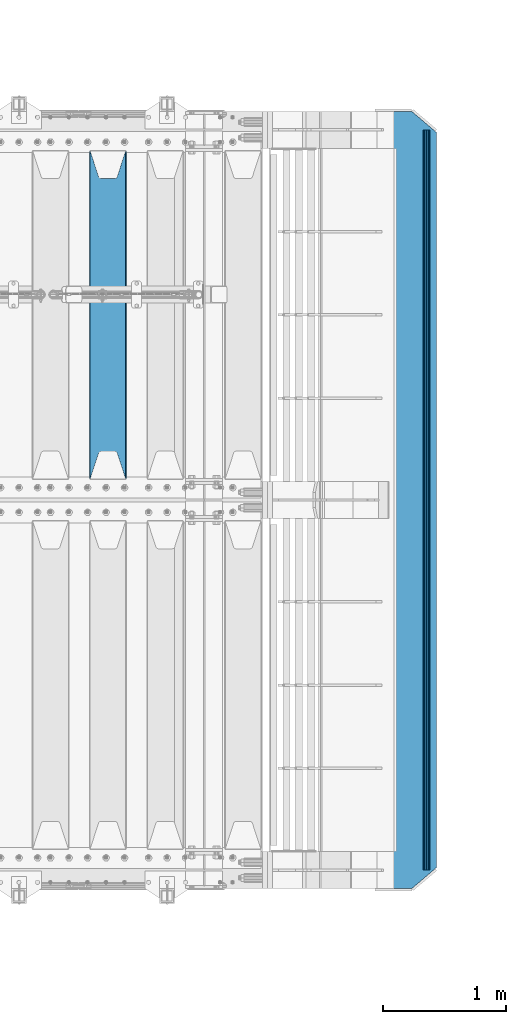
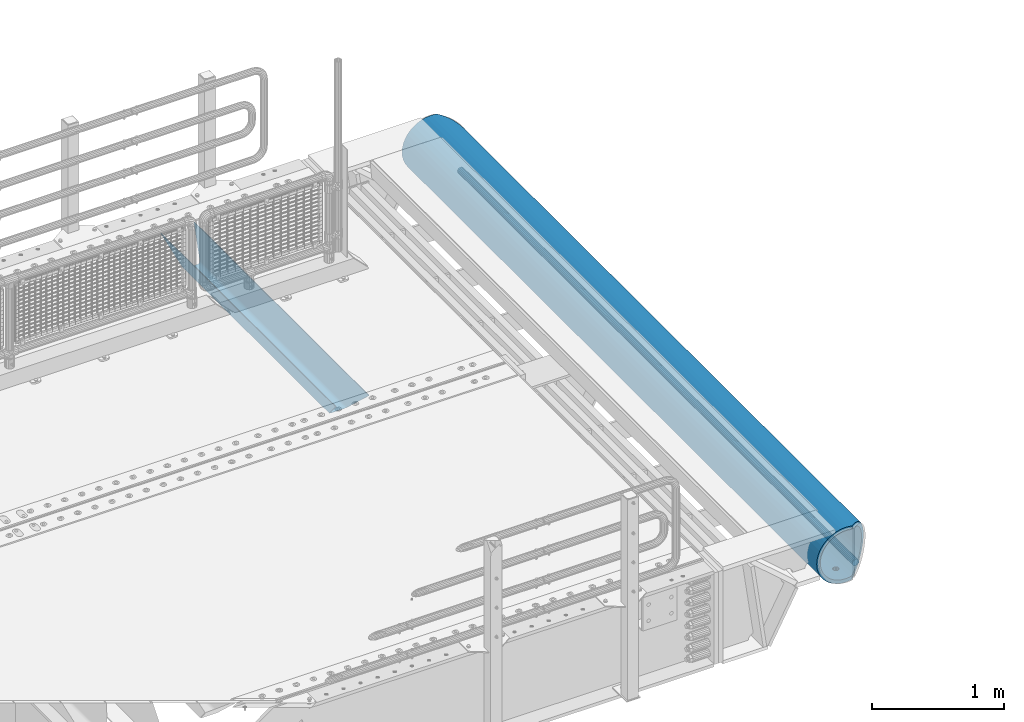
# One storey, part 110 of 208: 3 beams.
"""IFC2X3 building model written with IfcOpenShell, lengths in millimetres."""

from ifc_helpers import new_model, si_unit, frame, origin_with_axes, place, context, subcontext, project, spatial, faceted_brep, material, type_object, element, save


model = new_model("IFC2X3")

# Units and contexts
model_context = context("Model", 3, precision=1e-05, world=origin_with_axes())
body_context = subcontext(model_context, "Body", "Model", "MODEL_VIEW")
ifc_project = project(units=[si_unit("LENGTHUNIT", "METRE", prefix="MILLI"), si_unit("AREAUNIT", "SQUARE_METRE"), si_unit("VOLUMEUNIT", "CUBIC_METRE"), si_unit("MASSUNIT", "GRAM", prefix="KILO"), si_unit("TIMEUNIT", "SECOND"), si_unit("PLANEANGLEUNIT", "RADIAN"), si_unit("SOLIDANGLEUNIT", "STERADIAN"), si_unit("THERMODYNAMICTEMPERATUREUNIT", "DEGREE_CELSIUS"), si_unit("LUMINOUSINTENSITYUNIT", "LUMEN")], contexts=[model_context])

# Site, building, storey
site_placement = place(None, origin_with_axes())
site = spatial("IfcSite", under=ifc_project, at=site_placement, CompositionType="ELEMENT")
building_placement = place(site_placement, origin_with_axes())
building = spatial("IfcBuilding", under=site, at=building_placement, Name="Standard", CompositionType="ELEMENT")
storey_placement = place(building_placement, origin_with_axes())
storey = spatial("IfcBuildingStorey", under=building, at=storey_placement, Name="Undefined", CompositionType="ELEMENT", Elevation=0.0)

# Beams
ifc_material = material(Name="STEEL/S355N")
beam_type_1 = type_object("IfcBeamType", PredefinedType="NOTDEFINED")
beam_1_placement = place(storey_placement, frame((-26885.0, 3175.0, -115.0), z_axis=(0.0, 0.0, 1.0), x_axis=(0.0, 1.0, 0.0)))
element("IfcBeam", 1, at=beam_1_placement, inside=storey, type_object=beam_type_1, material=ifc_material, context=body_context, shape_type="Brep", body=[
    faceted_brep([(0.0, 150.0, 115.0), (0.0, 143.689999999999, 115.0), (2650.00000000297, 143.689999999999, 115.0), (2650.00000000297, 150.0, 115.0), (2650.00000000297, 142.059565218402, 110.0000000031), (2650.00000000297, 148.369565218403, 110.0000000031), (2441.90079219208, -80.1103600731112, -98.0992078077845), (2437.7588105432, -77.5672621345584, -102.241189456673), (2434.06523489746, -74.4080125315522, -105.934765102404), (2430.91086095089, -70.710272125576, -109.089139048974), (2428.37322971128, -66.5649389910068, -111.626770288588), (2426.51472138055, -62.0739139532889, -113.485278619323), (2425.38102192091, -57.3475956567672, -114.618978078955), (2424.99999999987, -52.5021667386536, -115.0), (2424.99999999987, 52.5021667386536, -115.0), (2425.38102192091, 57.3475956567672, -114.618978078955), (2426.51472138055, 62.0739139532889, -113.485278619323), (2428.37322971128, 66.5649389910068, -111.626770288588), (2430.91086095089, 70.710272125576, -109.089139048974), (2434.06523489746, 74.4080125315522, -105.934765102404), (2437.7588105432, 77.5672621345584, -102.241189456673), (2441.90079219208, 80.1103600731112, -98.0992078077846), (2446.38936140511, 81.9747917625791, -93.6106385947584), (2448.24948500409, 76.2713538057251, -91.7505149957729), (2444.62967112262, 74.76777986261, -95.3703288772456), (2441.28936334126, 72.7168944282894, -98.710636658607), (2438.31067330438, 70.1691124903846, -101.689326695487), (2435.76682334747, 67.1870637758839, -104.233176652398), (2433.72034654133, 63.8440531834895, -106.279653458539), (2432.22154950041, 60.222258798236, -107.778450499454), (2431.30727574265, 56.4107117849089, -108.692724257221), (2430.99999999987, 52.5031078186876, -109.0), (2430.99999999987, -52.5031078186876, -109.0), (2431.30727574265, -56.4107117849089, -108.692724257221), (2432.22154950041, -60.222258798236, -107.778450499454), (2433.72034654133, -63.8440531834895, -106.279653458539), (2435.76682334747, -67.1870637758839, -104.233176652398), (2438.31067330438, -70.1691124903846, -101.689326695487), (2441.28936334126, -72.7168944282894, -98.7106366586071), (2444.62967112262, -74.76777986261, -95.3703288772457), (2448.24948500409, -76.2713538057251, -91.7505149957729), (2650.00000000297, -142.059565218402, 110.0000000031), (2650.00000000297, -148.369565218403, 110.0000000031), (2446.38936140511, -81.9747917625791, -93.6106385947584), (2650.00000000297, -143.689999999999, 115.0), (2650.00000000297, -150.0, 115.0), (0.0, -143.689999999999, 115.0), (0.0, -150.0, 115.0), (0.0, -148.369565218261, 110.000000002663), (203.610638597421, -81.9747917625791, -93.6106385947584), (208.099207810448, -80.1103600731112, -98.0992078077845), (212.241189459336, -77.5672621345584, -102.241189456673), (215.934765105067, -74.4080125315522, -105.934765102404), (219.089139051637, -70.710272125576, -109.089139048974), (221.626770291251, -66.5649389910068, -111.626770288588), (223.485278621986, -62.0739139532889, -113.485278619323), (224.618978081618, -57.3475956567672, -114.618978078955), (225.000000002663, -52.5021667386536, -115.0), (225.000000002663, 52.5021667386536, -115.0), (224.618978081618, 57.3475956567672, -114.618978078955), (223.485278621986, 62.0739139532889, -113.485278619323), (221.626770291251, 66.5649389910068, -111.626770288588), (219.089139051637, 70.710272125576, -109.089139048974), (215.934765105067, 74.4080125315522, -105.934765102404), (212.241189459336, 77.5672621345584, -102.241189456673), (208.099207810448, 80.1103600731112, -98.0992078077846), (203.610638597421, 81.9747917625791, -93.6106385947584), (0.0, 148.369565218261, 110.000000002663), (0.0, 142.05956521826, 110.000000002663), (201.750514998436, 76.2713538057251, -91.7505149957729), (205.370328879908, 74.76777986261, -95.3703288772456), (208.71063666127, 72.7168944282894, -98.710636658607), (211.68932669815, 70.1691124903846, -101.689326695487), (214.233176655061, 67.1870637758839, -104.233176652398), (216.279653461202, 63.8440531834895, -106.279653458539), (217.778450502116, 60.222258798236, -107.778450499454), (218.692724259884, 56.4107117849089, -108.692724257221), (219.000000002663, 52.5031078186876, -109.0), (219.000000002663, -52.5031078186876, -109.0), (218.692724259884, -56.4107117849089, -108.692724257221), (217.778450502116, -60.222258798236, -107.778450499454), (216.279653461202, -63.8440531834895, -106.279653458539), (214.233176655061, -67.1870637758839, -104.233176652398), (211.68932669815, -70.1691124903846, -101.689326695487), (208.71063666127, -72.7168944282894, -98.7106366586071), (205.370328879908, -74.76777986261, -95.3703288772457), (201.750514998436, -76.2713538057251, -91.7505149957729), (0.0, -142.05956521826, 110.000000002663)], [[[0, 1, 2, 3]], [[3, 2, 4, 5]], [[6, 7, 8, 9, 10, 11, 12, 13, 14, 15, 16, 17, 18, 19, 20, 21, 22, 5, 4, 23, 24, 25, 26, 27, 28, 29, 30, 31, 32, 33, 34, 35, 36, 37, 38, 39, 40, 41, 42, 43]], [[44, 45, 42, 41]], [[46, 47, 45, 44]], [[43, 42, 45, 47, 48, 49]], [[6, 43, 49, 50]], [[7, 6, 50, 51]], [[8, 7, 51, 52]], [[9, 8, 52, 53]], [[10, 9, 53, 54]], [[11, 10, 54, 55]], [[12, 11, 55, 56]], [[13, 12, 56, 57]], [[14, 13, 57, 58]], [[15, 14, 58, 59]], [[16, 15, 59, 60]], [[17, 16, 60, 61]], [[18, 17, 61, 62]], [[19, 18, 62, 63]], [[20, 19, 63, 64]], [[21, 20, 64, 65]], [[22, 21, 65, 66]], [[0, 3, 5, 22, 66, 67]], [[1, 0, 67, 68]], [[23, 4, 2, 1, 68, 69]], [[24, 23, 69, 70]], [[25, 24, 70, 71]], [[26, 25, 71, 72]], [[27, 26, 72, 73]], [[28, 27, 73, 74]], [[29, 28, 74, 75]], [[30, 29, 75, 76]], [[31, 30, 76, 77]], [[32, 31, 77, 78]], [[33, 32, 78, 79]], [[34, 33, 79, 80]], [[35, 34, 80, 81]], [[36, 35, 81, 82]], [[37, 36, 82, 83]], [[38, 37, 83, 84]], [[39, 38, 84, 85]], [[40, 39, 85, 86]], [[46, 44, 41, 40, 86, 87]], [[47, 46, 87, 48]], [[86, 85, 84, 83, 82, 81, 80, 79, 78, 77, 76, 75, 74, 73, 72, 71, 70, 69, 68, 67, 66, 65, 64, 63, 62, 61, 60, 59, 58, 57, 56, 55, 54, 53, 52, 51, 50, 49, 48, 87]]]),
])
beam_type_2 = type_object("IfcBeamType", Name="D60", PredefinedType="NOTDEFINED")
beam_2_placement = place(storey_placement, frame((-24303.2474739935, 1.30739863379809e-14, -478.0), z_axis=(0.0, 0.0, 1.0), x_axis=(0.0, 1.0, 0.0)))
element("IfcBeam", 2, at=beam_2_placement, inside=storey, type_object=beam_type_2, material=ifc_material, ObjectType="D60", context=body_context, shape_type="Brep", body=[
    faceted_brep([(0.0, -30.0, 0.0), (-1.73472347597681e-18, -27.7163859753418, -11.4805029709527), (6000.00000000114, -27.7163859753418, -11.4805029709527), (6000.00000000114, -30.0, 0.0), (-1.73472347597681e-18, -21.2132034355964, -21.2132034355964), (6000.00000000114, -21.2132034355964, -21.2132034355964), (0.0, -11.4805029709532, -27.7163859753386), (6000.00000000114, -11.4805029709532, -27.7163859753386), (0.0, 0.0, -30.0), (6000.00000000114, 0.0, -30.0), (-1.73472347597681e-18, 11.4805029709496, -27.7163859753386), (6000.00000000114, 11.4805029709496, -27.7163859753386), (-1.73472347597681e-18, 21.2132034355964, -21.2132034355964), (6000.00000000114, 21.2132034355964, -21.2132034355964), (-1.73472347597681e-18, 27.7163859753382, -11.4805029709527), (6000.00000000114, 27.7163859753382, -11.4805029709527), (-3.46944695195361e-18, 29.9999999999964, 0.0), (6000.00000000114, 29.9999999999964, 0.0), (-1.73472347597681e-18, 27.7163859753382, 11.4805029709527), (6000.00000000114, 27.7163859753382, 11.4805029709527), (-1.73472347597681e-18, 21.2132034355964, 21.2132034355964), (6000.00000000114, 21.2132034355964, 21.2132034355964), (-1.73472347597681e-18, 11.4805029709496, 27.7163859753386), (6000.00000000114, 11.4805029709496, 27.7163859753386), (0.0, 0.0, 30.0), (6000.00000000114, 0.0, 30.0), (0.0, -11.4805029709532, 27.7163859753386), (6000.00000000114, -11.4805029709532, 27.7163859753386), (-1.73472347597681e-18, -21.2132034355964, 21.2132034355964), (6000.00000000114, -21.2132034355964, 21.2132034355964), (-1.73472347597681e-18, -27.7163859753418, 11.4805029709527), (6000.00000000114, -27.7163859753418, 11.4805029709527)], [[[0, 1, 2, 3]], [[1, 4, 5, 2]], [[4, 6, 7, 5]], [[6, 8, 9, 7]], [[8, 10, 11, 9]], [[10, 12, 13, 11]], [[12, 14, 15, 13]], [[14, 16, 17, 15]], [[16, 18, 19, 17]], [[18, 20, 21, 19]], [[20, 22, 23, 21]], [[22, 24, 25, 23]], [[24, 26, 27, 25]], [[26, 28, 29, 27]], [[28, 30, 31, 29]], [[30, 0, 3, 31]], [[5, 7, 9, 11, 13, 15, 17, 19, 21, 23, 25, 27, 29, 31, 3, 2]], [[30, 28, 26, 24, 22, 20, 18, 16, 14, 12, 10, 8, 6, 4, 1, 0]]]),
])
beam_type_3 = type_object("IfcBeamType", PredefinedType="NOTDEFINED")
beam_3_placement = place(storey_placement, frame((-24477.0011701094, 6150.0, -254.000000000001), z_axis=(0.0, 0.0, 1.0), x_axis=(0.0, -1.0, 0.0)))
element("IfcBeam", 3, at=beam_3_placement, inside=storey, type_object=beam_type_3, material=ifc_material, context=body_context, shape_type="Brep", body=[
    faceted_brep([(4659.56708580913, 23.1006844286749, -220.181936706647), (4659.56708580913, 23.1006844286749, -252.181936706647), (4667.67766952966, 17.6813656455561, -252.608446344705), (4667.67766952966, 17.6813656455561, -220.608446344705), (4673.09698831278, 9.57078192502013, -253.246763126855), (4673.09698831278, 9.57078192502013, -221.246763126855), (4675.0, 0.0, -254.0), (4675.0, 0.0, -222.0), (4673.09698831278, -9.5633896932377, -253.247344908112), (4673.09698831278, -9.5633896932377, -221.247344908113), (4667.67766952966, -17.6739734137736, -252.609028125962), (4667.67766952966, -17.6739734137736, -220.609028125963), (4659.56708580913, -23.0932921968924, -252.182518487904), (4659.56708580913, -23.0932921968924, -220.182518487905), (4650.0, -24.9963038841088, -252.032748220013), (4650.0, -24.9963038841088, -220.032748220014), (4640.43291419087, -23.0932921968924, -252.182518487904), (4640.43291419087, -23.0932921968924, -220.182518487905), (4632.32233047034, -17.6739734137736, -252.609028125962), (4632.32233047034, -17.6739734137736, -220.609028125963), (4626.90301168722, -9.5633896932377, -253.247344908112), (4626.90301168722, -9.5633896932377, -221.247344908113), (4625.0, 0.0, -254.0), (4625.0, 0.0, -222.0), (4626.90301168722, 9.57078192502013, -253.246763126855), (4626.90301168722, 9.57078192502013, -221.246763126855), (4632.32233047034, 17.6813656455561, -252.608446344705), (4632.32233047034, 17.6813656455561, -220.608446344705), (4640.43291419087, 23.1006844286749, -252.181936706647), (4640.43291419087, 23.1006844286749, -220.181936706647), (4650.0, 25.0036961158912, -252.032166438756), (4650.0, 25.0036961158912, -220.032166438756), (1632.32233047034, -17.6776695296612, -220.608737235334), (1632.32233047034, -17.6776695296612, -252.608737235333), (1626.90301168722, -9.56708580912527, -253.247054017483), (1626.90301168722, -9.56708580912527, -221.247054017484), (1640.43291419087, -23.09698831278, -220.182227597276), (1640.43291419087, -23.09698831278, -252.182227597275), (1650.0, -24.9999999999964, -220.032457329384), (1650.0, -24.9999999999964, -252.032457329384), (1659.56708580913, -23.09698831278, -220.182227597276), (1659.56708580913, -23.09698831278, -252.182227597275), (1667.67766952966, -17.6776695296612, -220.608737235334), (1667.67766952966, -17.6776695296612, -252.608737235333), (1673.09698831278, -9.56708580912527, -221.247054017484), (1673.09698831278, -9.56708580912527, -253.247054017483), (1675.0, 0.0, -222.0), (1675.0, 0.0, -254.0), (1673.09698831278, 9.56708580913255, -221.247054017484), (1673.09698831278, 9.56708580913255, -253.247054017484), (1667.67766952966, 17.6776695296685, -220.608737235333), (1667.67766952966, 17.6776695296685, -252.608737235334), (1659.56708580913, 23.0969883127873, -220.182227597275), (1659.56708580913, 23.0969883127873, -252.182227597276), (1650.0, 25.0000000000036, -220.032457329384), (1650.0, 25.0000000000036, -252.032457329385), (1640.43291419087, 23.0969883127873, -220.182227597275), (1640.43291419087, 23.0969883127873, -252.182227597276), (1632.32233047034, 17.6776695296685, -220.608737235333), (1632.32233047034, 17.6776695296685, -252.608737235334), (1626.90301168722, 9.56708580913255, -221.247054017484), (1626.90301168722, 9.56708580913255, -253.247054017484), (1625.0, 0.0, -222.0), (1625.0, 0.0, -254.0), (132.322330470337, -17.6776695296612, -220.608737235334), (132.322330470337, -17.6776695296612, -252.608737235334), (126.903011687219, -9.56708580912527, -253.247054017484), (126.903011687219, -9.56708580912527, -221.247054017484), (140.432914190874, -23.09698831278, -220.182227597276), (140.432914190874, -23.09698831278, -252.182227597276), (150.000000000001, -24.9999999999964, -220.032457329385), (150.000000000001, -24.9999999999964, -252.032457329385), (159.567085809128, -23.09698831278, -220.182227597276), (159.567085809128, -23.09698831278, -252.182227597276), (167.677669529665, -17.6776695296612, -220.608737235334), (167.677669529665, -17.6776695296612, -252.608737235334), (173.096988312783, -9.56708580912527, -221.247054017484), (173.096988312783, -9.56708580912527, -253.247054017484), (175.000000000002, 0.0, -222.0), (175.000000000002, 0.0, -254.0), (173.096988312783, 9.56708580913255, -221.247054017484), (173.096988312783, 9.56708580913255, -253.247054017484), (167.677669529665, 17.6776695296685, -220.608737235334), (167.677669529665, 17.6776695296685, -252.608737235333), (159.567085809128, 23.0969883127873, -220.182227597276), (159.567085809128, 23.0969883127873, -252.182227597275), (150.000000000001, 25.0000000000036, -220.032457329384), (150.000000000001, 25.0000000000036, -252.032457329384), (140.432914190874, 23.0969883127873, -220.182227597276), (140.432914190874, 23.0969883127873, -252.182227597275), (132.322330470337, 17.6776695296685, -220.608737235334), (132.322330470337, 17.6776695296685, -252.608737235333), (126.903011687219, 9.56708580913255, -221.247054017484), (126.903011687219, 9.56708580913255, -253.247054017484), (125.000000000001, 0.0, -222.0), (125.000000000001, 0.0, -254.0), (0.0, -34.7284512389306, -219.266811612121), (0.0, -68.6017727512371, -211.134546617524), (6300.0, -68.6017727512371, -211.134546617524), (6300.0, -34.7284512389306, -219.266811612121), (0.0, -100.785890942181, -197.803448369818), (6300.0, -100.785890942181, -197.803448369818), (0.0, -130.48832600893, -179.601772751238), (6300.0, -130.48832600893, -179.601772751238), (0.0, -156.977705423415, -156.977705423414), (6300.0, -156.977705423415, -156.977705423414), (0.0, -179.601772751237, -130.488326008929), (6300.0, -179.601772751237, -130.488326008929), (0.0, -197.803448369817, -100.785890942179), (6300.0, -197.803448369817, -100.785890942179), (0.0, -211.134546617523, -68.6017727512383), (6300.0, -211.134546617523, -68.6017727512383), (0.0, -219.26681161212, -34.7284512389313), (6300.0, -219.26681161212, -34.7284512389313), (0.0, -222.0, 0.0), (6300.0, -222.0, 0.0), (0.0, -219.26681161212, 34.7284512389313), (6300.0, -219.26681161212, 34.7284512389313), (0.0, -211.134546617523, 68.6017727512384), (6300.0, -211.134546617523, 68.6017727512384), (0.0, -197.803448369817, 100.785890942179), (6300.0, -197.803448369817, 100.785890942179), (0.0, -179.601772751237, 130.488326008929), (6300.0, -179.601772751237, 130.488326008929), (0.0, -156.977705423415, 156.977705423414), (6300.0, -156.977705423415, 156.977705423414), (0.0, -130.48832600893, 179.601772751238), (6300.0, -130.48832600893, 179.601772751238), (0.0, -100.785890942181, 197.803448369818), (6300.0, -100.785890942181, 197.803448369818), (0.0, -68.6017727512371, 211.134546617524), (6300.0, -68.6017727512371, 211.134546617524), (0.0, -34.7284512389306, 219.266811612121), (6300.0, -34.7284512389306, 219.266811612121), (0.0, 0.0, 222.0), (6300.0, 0.0, 222.0), (0.0, 34.7284512389306, 219.266811612121), (6300.0, 34.7284512389306, 219.266811612121), (6287.59163509751, 68.6017727512371, 211.134546617524), (6300.0, 54.0036961158912, 214.639234741094), (0.0, 54.0000000000036, 214.64012210001), (12.4115067427265, 68.6017727512371, 211.134546617524), (6260.23513515893, 100.785890942181, 197.803448369818), (39.7680069938233, 100.785890942181, 197.803448369818), (6234.98806583554, 130.48832600893, 179.601772751238), (65.0150766056395, 130.48832600893, 179.601772751238), (6212.47209376429, 156.977705423415, 156.977705423414), (87.5310489341164, 156.977705423415, 156.977705423414), (6193.2416369038, 179.601772751237, 130.488326008929), (106.761506014299, 179.601772751237, 130.488326008929), (6177.7702129242, 197.803448369817, 100.785890942179), (122.232930170642, 197.803448369817, 100.785890942179), (6166.43877963058, 211.134546617523, 68.6017727512383), (133.564363593708, 211.134546617523, 68.6017727512383), (6159.52635451751, 219.26681161212, 34.7284512389312), (140.476788785748, 219.26681161212, 34.7284512389312), (6157.20314443229, 222.0, -2.8421709430404e-14), (142.799998897512, 222.0, -2.8421709430404e-14), (6159.52635451751, 219.26681161212, -34.7284512389313), (140.476788785748, 219.26681161212, -34.7284512389313), (6166.43877963058, 211.134546617523, -68.6017727512383), (133.564363593708, 211.134546617523, -68.6017727512383), (6177.7702129242, 197.803448369817, -100.785890942179), (122.232930170642, 197.803448369817, -100.785890942179), (6193.2416369038, 179.601772751237, -130.488326008929), (106.761506014299, 179.601772751237, -130.488326008929), (6212.47209376429, 156.977705423415, -156.977705423414), (87.5310489341164, 156.977705423415, -156.977705423414), (6234.98806583554, 130.48832600893, -179.601772751238), (65.0150766056395, 130.48832600893, -179.601772751238), (6260.23513515893, 100.785890942181, -197.803448369818), (39.7680069938233, 100.785890942181, -197.803448369818), (6287.59163509751, 68.6017727512371, -211.134546617524), (12.4115067427265, 68.6017727512371, -211.134546617524), (0.0, 34.7284512389306, -219.266811612121), (6300.0, 34.7284512389306, -219.266811612121), (6300.0, 54.0036961158912, -214.639234741094), (0.0, 54.0000000000036, -214.64012210001), (6140.5700428826, 241.56835513897, -78.4903165712366), (6153.53483593025, 226.315657143845, -115.313586933845), (146.468307441459, 226.315657143845, -115.313586933845), (159.433100637219, 241.56835513897, -78.4903165712366), (6171.23637507808, 205.490316571235, -149.297454082288), (128.766768091403, 205.490316571235, -149.297454082288), (6193.23878968423, 179.605122421384, -179.605122421383), (106.764353233899, 179.605122421384, -179.605122421383), (6219.00030727927, 149.297454082287, -205.490316571237), (81.0028353445578, 149.297454082287, -205.490316571237), (6247.88659380243, 115.313586933844, -226.315657143845), (52.116548491399, 115.313586933844, -226.315657143845), (6279.18637301142, 78.4903165712349, -241.568355138969), (20.8167689248312, 78.4903165712349, -241.568355138969), (6300.0, 54.0036961158912, -247.447072591954), (6300.0, 39.7343541202172, -250.872838511165), (0.0, 39.7343541202172, -250.872838511165), (0.0, 54.0000000000036, -247.447959950869), (0.0, 0.0, -222.0), (0.0, 0.0, -254.0), (0.0, -39.7343541202172, -250.872838511165), (0.0, -78.4903165712349, -241.568355138969), (0.0, -115.313586933844, -226.315657143845), (0.0, -149.297454082287, -205.490316571237), (0.0, -179.605122421384, -179.605122421383), (0.0, -205.490316571235, -149.297454082288), (0.0, -226.315657143845, -115.313586933845), (0.0, -241.56835513897, -78.4903165712367), (0.0, -250.872838511164, -39.7343541202187), (0.0, -254.0, 0.0), (0.0, -250.872838511164, 39.7343541202187), (0.0, -241.56835513897, 78.4903165712366), (0.0, -226.315657143845, 115.313586933845), (0.0, -205.490316571235, 149.297454082288), (0.0, -179.605122421384, 179.605122421383), (0.0, -149.297454082287, 205.490316571237), (0.0, -115.313586933844, 226.315657143845), (0.0, -78.4903165712349, 241.568355138969), (0.0, -39.7343541202172, 250.872838511165), (0.0, 0.0, 254.0), (0.0, 39.7343541202172, 250.872838511165), (0.0, 54.0000000000036, 247.447959950869), (6300.0, -39.7343541202172, -250.872838511165), (6300.0, -78.4903165712349, -241.568355138969), (6300.0, -115.313586933844, -226.315657143845), (6300.0, -149.297454082287, -205.490316571237), (6300.0, -179.605122421384, -179.605122421383), (6300.0, -205.490316571235, -149.297454082288), (6300.0, -226.315657143845, -115.313586933845), (6300.0, -241.56835513897, -78.4903165712367), (6300.0, -250.872838511164, -39.7343541202187), (6300.0, -254.0, 0.0), (6300.0, -250.872838511164, 39.7343541202187), (6300.0, -241.56835513897, 78.4903165712366), (6300.0, -226.315657143845, 115.313586933845), (6300.0, -205.490316571235, 149.297454082288), (6300.0, -179.605122421384, 179.605122421383), (6300.0, -149.297454082287, 205.490316571237), (6300.0, -115.313586933844, 226.315657143845), (6300.0, -78.4903165712349, 241.568355138969), (6300.0, -39.7343541202172, 250.872838511165), (6300.0, 0.0, 254.0), (6300.0, 39.7343541202172, 250.872838511165), (6300.0, 54.0036961158912, 247.447072591954), (6279.18637301142, 78.4903165712349, 241.568355138969), (20.8167689248312, 78.4903165712349, 241.568355138969), (6247.88659380243, 115.313586933844, 226.315657143845), (52.116548491399, 115.313586933844, 226.315657143845), (6219.00030727927, 149.297454082287, 205.490316571237), (81.0028353445578, 149.297454082287, 205.490316571237), (6193.23878968423, 179.605122421384, 179.605122421383), (106.764353233899, 179.605122421384, 179.605122421383), (6171.23637507808, 205.490316571235, 149.297454082288), (128.766768091403, 205.490316571235, 149.297454082288), (6153.53483593025, 226.315657143845, 115.313586933845), (146.468307441459, 226.315657143845, 115.313586933845), (6140.5700428826, 241.56835513897, 78.4903165712367), (159.433100637219, 241.56835513897, 78.4903165712367), (6129.99999983226, 254.003700142144, 0.0), (6132.66123216765, 250.872838511164, -39.7343541202186), (167.341911442528, 250.872838511164, -39.7343541202186), (170.000001295226, 254.000003067897, 5.6843418860808e-14), (6132.66123216765, 250.872838511164, 39.7343541202187), (167.341911442528, 250.872838511164, 39.7343541202187), (6300.0, 0.0, -254.0), (6300.0, 0.0, -222.0), (6132.32233047034, -17.6739734137809, -220.609028125962), (6132.32233047034, -17.6739734137809, -252.609028125962), (6126.90301168722, -9.56338969324497, -253.247344908112), (6126.90301168722, -9.56338969324497, -221.247344908112), (6140.43291419087, -23.0932921968997, -220.182518487904), (6140.43291419087, -23.0932921968997, -252.182518487904), (6150.0, -24.9963038841161, -220.032748220013), (6150.0, -24.9963038841161, -252.032748220013), (6159.56708580913, -23.0932921968997, -220.182518487904), (6159.56708580913, -23.0932921968997, -252.182518487904), (6167.67766952966, -17.6739734137809, -220.609028125962), (6167.67766952966, -17.6739734137809, -252.609028125962), (6173.09698831278, -9.56338969324497, -221.247344908112), (6173.09698831278, -9.56338969324497, -253.247344908112), (6175.0, 0.0, -222.0), (6175.0, 0.0, -254.0), (6173.09698831278, 9.57078192501285, -221.246763126855), (6173.09698831278, 9.57078192501285, -253.246763126856), (6167.67766952966, 17.6813656455488, -220.608446344705), (6167.67766952966, 17.6813656455488, -252.608446344706), (6159.56708580913, 23.1006844286676, -220.181936706647), (6159.56708580913, 23.1006844286676, -252.181936706647), (6150.0, 25.0036961158839, -220.032166438756), (6150.0, 25.0036961158839, -252.032166438756), (6140.43291419087, 23.1006844286676, -220.181936706647), (6140.43291419087, 23.1006844286676, -252.181936706647), (6132.32233047034, 17.6813656455488, -220.608446344705), (6132.32233047034, 17.6813656455488, -252.608446344706), (6126.90301168722, 9.57078192501285, -221.246763126855), (6126.90301168722, 9.57078192501285, -253.246763126856), (6125.0, 0.0, -222.0), (6125.0, 0.0, -254.0), (3175.0, 0.0, -222.0), (3173.09698831278, -9.56708580912527, -221.247054017484), (3167.67766952966, -17.6776695296612, -220.608737235334), (3159.56708580913, -23.09698831278, -220.182227597276), (3150.0, -24.9999999999964, -220.032457329384), (3140.43291419087, -23.09698831278, -220.182227597276), (3132.32233047034, -17.6776695296612, -220.608737235334), (3126.90301168722, -9.56708580912527, -221.247054017484), (3125.0, 0.0, -222.0), (3126.90301168722, 9.56708580913255, -221.247054017483), (3132.32233047034, 17.6776695296685, -220.608737235333), (3140.43291419087, 23.0969883127873, -220.182227597275), (3150.0, 25.0000000000036, -220.032457329384), (3159.56708580913, 23.0969883127873, -220.182227597275), (3167.67766952966, 17.6776695296685, -220.608737235333), (3173.09698831278, 9.56708580913255, -221.247054017483), (3173.09698831278, 9.56708580913255, -253.247054017484), (3175.0, 0.0, -254.0), (3167.67766952966, 17.6776695296685, -252.608737235333), (3159.56708580913, 23.0969883127873, -252.182227597275), (3150.0, 25.0000000000036, -252.032457329384), (3140.43291419087, 23.0969883127873, -252.182227597275), (3132.32233047034, 17.6776695296685, -252.608737235333), (3126.90301168722, 9.56708580913255, -253.247054017484), (3125.0, 0.0, -254.0), (3126.90301168722, -9.56708580912527, -253.247054017485), (3132.32233047034, -17.6776695296612, -252.608737235334), (3140.43291419087, -23.09698831278, -252.182227597276), (3150.0, -24.9999999999964, -252.032457329385), (3159.56708580913, -23.09698831278, -252.182227597276), (3167.67766952966, -17.6776695296612, -252.608737235334), (3173.09698831278, -9.56708580912527, -253.247054017485)], [[[0, 1, 2, 3]], [[3, 2, 4, 5]], [[5, 4, 6, 7]], [[7, 6, 8, 9]], [[9, 8, 10, 11]], [[11, 10, 12, 13]], [[13, 12, 14, 15]], [[15, 14, 16, 17]], [[17, 16, 18, 19]], [[19, 18, 20, 21]], [[21, 20, 22, 23]], [[23, 22, 24, 25]], [[25, 24, 26, 27]], [[27, 26, 28, 29]], [[29, 28, 30, 31]], [[31, 30, 1, 0]], [[32, 33, 34, 35]], [[36, 37, 33, 32]], [[38, 39, 37, 36]], [[40, 41, 39, 38]], [[42, 43, 41, 40]], [[44, 45, 43, 42]], [[46, 47, 45, 44]], [[48, 49, 47, 46]], [[50, 51, 49, 48]], [[52, 53, 51, 50]], [[54, 55, 53, 52]], [[56, 57, 55, 54]], [[58, 59, 57, 56]], [[60, 61, 59, 58]], [[62, 63, 61, 60]], [[35, 34, 63, 62]], [[64, 65, 66, 67]], [[68, 69, 65, 64]], [[70, 71, 69, 68]], [[72, 73, 71, 70]], [[74, 75, 73, 72]], [[76, 77, 75, 74]], [[78, 79, 77, 76]], [[80, 81, 79, 78]], [[82, 83, 81, 80]], [[84, 85, 83, 82]], [[86, 87, 85, 84]], [[88, 89, 87, 86]], [[90, 91, 89, 88]], [[92, 93, 91, 90]], [[94, 95, 93, 92]], [[67, 66, 95, 94]], [[96, 97, 98, 99]], [[97, 100, 101, 98]], [[100, 102, 103, 101]], [[102, 104, 105, 103]], [[104, 106, 107, 105]], [[106, 108, 109, 107]], [[108, 110, 111, 109]], [[110, 112, 113, 111]], [[112, 114, 115, 113]], [[114, 116, 117, 115]], [[116, 118, 119, 117]], [[118, 120, 121, 119]], [[120, 122, 123, 121]], [[122, 124, 125, 123]], [[124, 126, 127, 125]], [[126, 128, 129, 127]], [[128, 130, 131, 129]], [[130, 132, 133, 131]], [[132, 134, 135, 133]], [[134, 136, 137, 135]], [[138, 139, 137, 136, 140, 141]], [[142, 138, 141, 143]], [[144, 142, 143, 145]], [[146, 144, 145, 147]], [[148, 146, 147, 149]], [[150, 148, 149, 151]], [[152, 150, 151, 153]], [[154, 152, 153, 155]], [[156, 154, 155, 157]], [[158, 156, 157, 159]], [[160, 158, 159, 161]], [[162, 160, 161, 163]], [[164, 162, 163, 165]], [[166, 164, 165, 167]], [[168, 166, 167, 169]], [[170, 168, 169, 171]], [[172, 170, 171, 173]], [[174, 175, 176, 172, 173, 177]], [[178, 179, 180, 181]], [[179, 182, 183, 180]], [[182, 184, 185, 183]], [[184, 186, 187, 185]], [[186, 188, 189, 187]], [[188, 190, 191, 189]], [[190, 192, 193, 194, 195, 191]], [[136, 134, 132, 130, 128, 126, 124, 122, 120, 118, 116, 114, 112, 110, 108, 106, 104, 102, 100, 97, 96, 196, 174, 177, 195, 194, 197, 198, 199, 200, 201, 202, 203, 204, 205, 206, 207, 208, 209, 210, 211, 212, 213, 214, 215, 216, 217, 218, 219, 140]], [[199, 198, 220, 221]], [[200, 199, 221, 222]], [[201, 200, 222, 223]], [[202, 201, 223, 224]], [[203, 202, 224, 225]], [[204, 203, 225, 226]], [[205, 204, 226, 227]], [[206, 205, 227, 228]], [[207, 206, 228, 229]], [[208, 207, 229, 230]], [[209, 208, 230, 231]], [[210, 209, 231, 232]], [[211, 210, 232, 233]], [[212, 211, 233, 234]], [[213, 212, 234, 235]], [[214, 213, 235, 236]], [[215, 214, 236, 237]], [[216, 215, 237, 238]], [[217, 216, 238, 239]], [[218, 217, 239, 240]], [[218, 240, 241, 242, 243, 219]], [[242, 244, 245, 243]], [[244, 246, 247, 245]], [[246, 248, 249, 247]], [[248, 250, 251, 249]], [[250, 252, 253, 251]], [[252, 254, 255, 253]], [[256, 257, 258, 259]], [[260, 256, 259, 261]], [[254, 260, 261, 255]], [[259, 258, 181, 180, 183, 185, 187, 189, 191, 195, 177, 173, 171, 169, 167, 165, 163, 161, 159, 157, 155, 153, 151, 149, 147, 145, 143, 141, 140, 219, 243, 245, 247, 249, 251, 253, 255, 261]], [[257, 178, 181, 258]], [[256, 260, 254, 252, 250, 248, 246, 244, 242, 241, 139, 138, 142, 144, 146, 148, 150, 152, 154, 156, 158, 160, 162, 164, 166, 168, 170, 172, 176, 192, 190, 188, 186, 184, 182, 179, 178, 257]], [[240, 239, 238, 237, 236, 235, 234, 233, 232, 231, 230, 229, 228, 227, 226, 225, 224, 223, 222, 221, 220, 262, 193, 192, 176, 175, 263, 99, 98, 101, 103, 105, 107, 109, 111, 113, 115, 117, 119, 121, 123, 125, 127, 129, 131, 133, 135, 137, 139, 241]], [[264, 265, 266, 267]], [[268, 269, 265, 264]], [[270, 271, 269, 268]], [[272, 273, 271, 270]], [[274, 275, 273, 272]], [[276, 277, 275, 274]], [[278, 279, 277, 276]], [[280, 281, 279, 278]], [[282, 283, 281, 280]], [[284, 285, 283, 282]], [[286, 287, 285, 284]], [[288, 289, 287, 286]], [[290, 291, 289, 288]], [[292, 293, 291, 290]], [[294, 295, 293, 292]], [[267, 266, 295, 294]], [[296, 297, 298, 299, 300, 301, 302, 303, 304, 46, 44, 42, 40, 38, 36, 32, 35, 62, 78, 76, 74, 72, 70, 68, 64, 67, 94, 196, 96, 99, 263, 278, 276, 274, 272, 270, 268, 264, 267, 294, 7, 9, 11, 13, 15, 17, 19, 21, 23]], [[3, 5, 7, 294, 292, 290, 288, 286, 284, 282, 280, 278, 263, 175, 174, 196, 94, 92, 90, 88, 86, 84, 82, 80, 78, 62, 60, 58, 56, 54, 52, 50, 48, 46, 304, 305, 306, 307, 308, 309, 310, 311, 296, 23, 25, 27, 29, 31, 0]], [[311, 312, 313, 296]], [[310, 314, 312, 311]], [[309, 315, 314, 310]], [[308, 316, 315, 309]], [[307, 317, 316, 308]], [[306, 318, 317, 307]], [[305, 319, 318, 306]], [[304, 320, 319, 305]], [[303, 321, 320, 304]], [[302, 322, 321, 303]], [[301, 323, 322, 302]], [[300, 324, 323, 301]], [[299, 325, 324, 300]], [[298, 326, 325, 299]], [[297, 327, 326, 298]], [[296, 313, 327, 297]], [[18, 16, 14, 12, 10, 8, 6, 295, 266, 265, 269, 271, 273, 275, 277, 279, 262, 220, 198, 197, 95, 66, 65, 69, 71, 73, 75, 77, 79, 63, 34, 33, 37, 39, 41, 43, 45, 47, 320, 321, 322, 323, 324, 325, 326, 327, 313, 22, 20]], [[26, 24, 22, 313, 312, 314, 315, 316, 317, 318, 319, 320, 47, 49, 51, 53, 55, 57, 59, 61, 63, 79, 81, 83, 85, 87, 89, 91, 93, 95, 197, 194, 193, 262, 279, 281, 283, 285, 287, 289, 291, 293, 295, 6, 4, 2, 1, 30, 28]]]),
])

save(model, "model.ifc")
